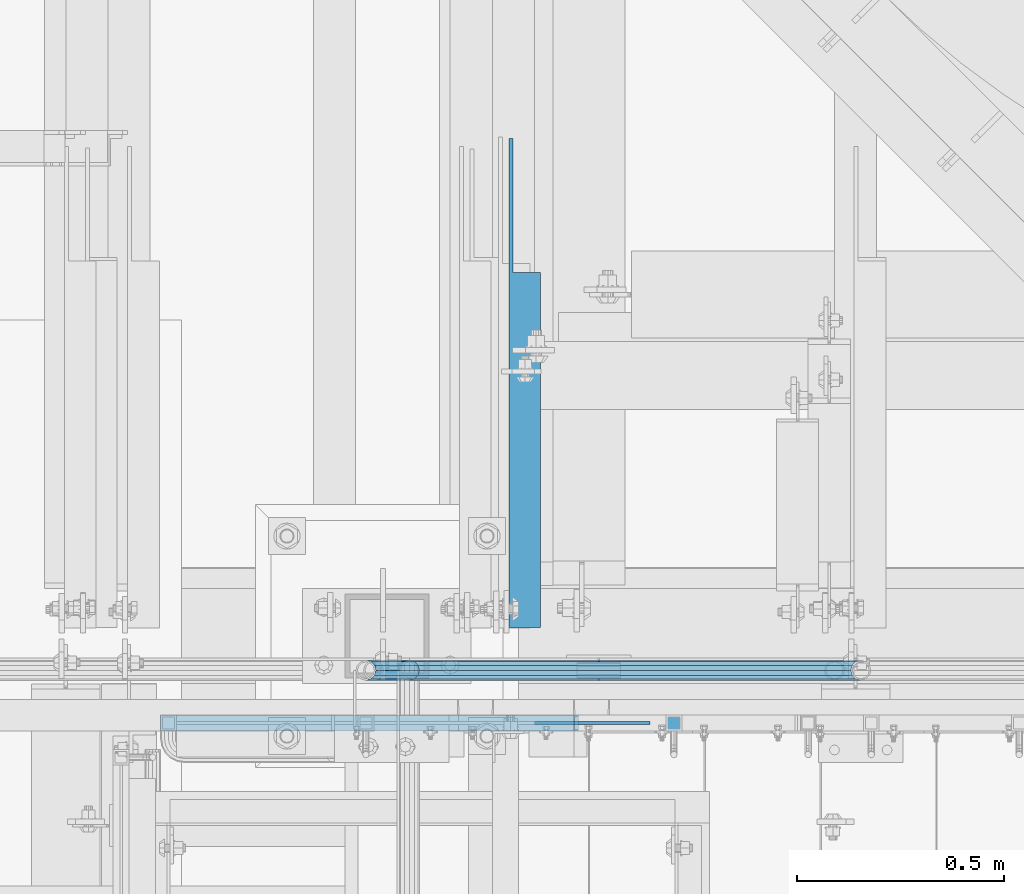
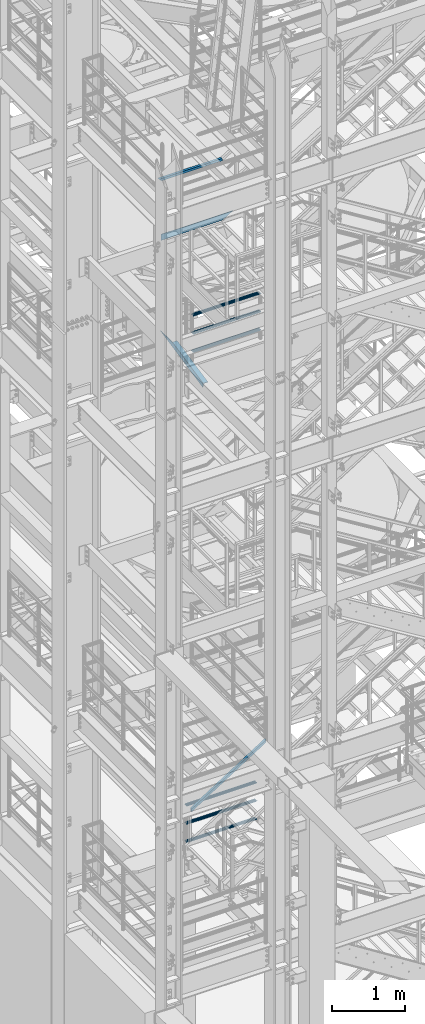
# One storey, part 967 of 1876: 9 beams, 1 member, 5 elements without a shape of their own.
"""IFC2X3 building model written with IfcOpenShell, lengths in millimetres."""

from ifc_helpers import new_model, si_unit, frame, origin_with_axes, place, context, subcontext, project, spatial, faceted_brep, material, type_object, element, aggregate, save


model = new_model("IFC2X3")

# Units and contexts
model_context = context("Model", 3, precision=1e-05, world=origin_with_axes())
body_context = subcontext(model_context, "Body", "Model", "MODEL_VIEW")
ifc_project = project(units=[si_unit("LENGTHUNIT", "METRE", prefix="MILLI"), si_unit("AREAUNIT", "SQUARE_METRE"), si_unit("VOLUMEUNIT", "CUBIC_METRE"), si_unit("MASSUNIT", "GRAM", prefix="KILO"), si_unit("TIMEUNIT", "SECOND"), si_unit("PLANEANGLEUNIT", "RADIAN"), si_unit("SOLIDANGLEUNIT", "STERADIAN"), si_unit("THERMODYNAMICTEMPERATUREUNIT", "DEGREE_CELSIUS"), si_unit("LUMINOUSINTENSITYUNIT", "LUMEN")], contexts=[model_context])

# Site, building, storey
site_placement = place(None, origin_with_axes())
site = spatial("IfcSite", under=ifc_project, at=site_placement, CompositionType="ELEMENT")
building_placement = place(site_placement, origin_with_axes())
building = spatial("IfcBuilding", under=site, at=building_placement, Name="Undefined", CompositionType="ELEMENT")
storey_placement = place(building_placement, origin_with_axes())
storey = spatial("IfcBuildingStorey", under=building, at=storey_placement, Name="Undefined", CompositionType="ELEMENT", Elevation=0.0)

# Assembly, beams
assembly_1_placement = place(storey_placement, origin_with_axes())
assembly_1 = element("IfcElementAssembly", 1, at=assembly_1_placement, inside=storey, Name="RAIL", AssemblyPlace="NOTDEFINED", PredefinedType="RIGID_FRAME")
ifc_material_1 = material()
beam_type_1 = type_object("IfcBeamType", Name="PIPE1-1/2SCH40", PredefinedType="NOTDEFINED")
beam_1_placement = place(assembly_1_placement, frame((2870.19999998821, -4654.55000114568, 13471.525), z_axis=(0.0, 0.0, 1.0), x_axis=(-1.0, 0.0, 0.0)))
beam_1 = element("IfcBeam", 2, at=beam_1_placement, type_object=beam_type_1, material=ifc_material_1, Name="RAIL", ObjectType="PIPE1-1/2SCH40", context=body_context, shape_type="Brep", body=[
    faceted_brep([(1068.12780699489, -12.0649999999996, 20.8971929933177), (1068.12780699489, -12.064999999986, 15.8661214311942), (1067.63437855703, -10.2235000000001, 17.7076214311801), (1064.89499998821, 0.0, 20.4470000000001), (1064.89499998821, 0.0, 24.1299999999992), (1067.63437855703, 10.2235000000001, 17.7076214311801), (1068.12780699489, 12.0650000000132, 15.8661214311669), (1068.12780699489, 12.0649999999996, 20.8971929933177), (1089.02499998822, 24.1300000000001, 0.0), (1076.95999998821, 20.8971929933186, 12.0650000000005), (1076.95999998821, 20.8971929933186, -12.0650000000005), (1073.77042842606, 17.7076214311801, 10.2235000000001), (1076.50980699488, 20.4470000000001, 0.0), (1073.77042842606, 17.7076214311801, -10.2235000000001), (1068.12780699489, 12.0650000000132, -15.8661214311669), (1068.12780699489, 12.0649999999996, -20.8971929933177), (1067.63437855703, 10.2235000000001, -17.7076214311801), (1064.89499998821, 0.0, -20.4470000000001), (1064.89499998821, 0.0, -24.1299999999992), (1068.12780699489, -12.064999999986, -15.8661214311942), (1068.12780699489, -12.0649999999996, -20.8971929933177), (1067.63437855703, -10.2235000000001, -17.7076214311801), (1089.02499998821, -24.1299999999865, 0.0), (1076.95999998821, -20.8971929933186, -12.0650000000005), (1076.95999998821, -20.8971929933186, 12.0650000000005), (1073.77042842609, -17.7076214311801, -10.2235000000001), (1076.50980699491, -20.4470000000001, 0.0), (1073.77042842609, -17.7076214311801, 10.2235000000001), (12.0650000000064, -20.8971929933177, -12.0649999999987), (20.8971929933249, -12.0650000000005, -20.8971929933177), (0.0, 24.1299999999992, 0.0), (12.0650000000064, 20.8971929933177, -12.0649999999987), (12.0650000000064, 20.8971929933177, 12.0649999999987), (20.8971929933249, 12.0650000000005, 20.8971929933177), (24.1300000000064, 0.0, 24.130000000001), (20.8971929933249, 12.0650000000005, -20.8971929933177), (24.1300000000063, 0.0, -24.130000000001), (24.1300000000063, 0.0, -20.4470000000001), (20.8971929933249, -12.0650000000005, -15.8661214311796), (21.3906214311868, -10.2235000000001, -17.7076214311819), (21.3906214311868, 10.2235000000001, -17.7076214311819), (20.8971929933249, 12.0650000000005, -15.8661214311796), (15.2545715621445, 17.7076214311801, -10.2235000000001), (12.5151929933249, 20.4470000000001, 0.0), (15.2545715621445, 17.7076214311801, 10.2235000000001), (20.8971929933249, 12.0650000000005, 15.8661214311796), (21.3906214311868, 10.2235000000001, 17.7076214311819), (24.1300000000064, 0.0, 20.4470000000001), (21.3906214311868, -10.2235000000001, 17.7076214311819), (20.8971929933249, -12.0650000000005, 15.8661214311796), (20.8971929933249, -12.0650000000005, 20.8971929933177), (12.0650000000064, -20.8971929933177, 12.0649999999987), (0.0, -24.1299999999992, 0.0), (15.2545715621445, -17.7076214311801, 10.2235000000001), (12.5151929933249, -20.4470000000001, 0.0), (15.2545715621445, -17.7076214311801, -10.2235000000001)], [[[0, 1, 2, 3, 4]], [[4, 3, 5, 6, 7]], [[8, 9, 10]], [[7, 6, 11, 12, 13, 14, 15, 10, 9]], [[16, 17, 18, 15, 14]], [[19, 20, 18, 17, 21]], [[22, 23, 24]], [[24, 23, 20, 19, 25, 26, 27, 1, 0]], [[28, 29, 20, 23]], [[30, 31, 32]], [[33, 34, 4, 7]], [[32, 33, 7, 9]], [[30, 32, 9, 8]], [[31, 30, 8, 10]], [[35, 31, 10, 15]], [[36, 35, 15, 18]], [[29, 36, 18, 20]], [[37, 36, 29, 38, 39]], [[40, 41, 35, 36, 37]], [[32, 31, 35, 41, 42, 43, 44, 45, 33]], [[33, 45, 46, 47, 34]], [[34, 47, 48, 49, 50]], [[34, 50, 0, 4]], [[50, 51, 24, 0]], [[51, 52, 22, 24]], [[52, 28, 23, 22]], [[51, 28, 52]], [[50, 49, 53, 54, 55, 38, 29, 28, 51]], [[55, 54, 26, 25]], [[21, 39, 38, 55, 25, 19]], [[37, 39, 21, 17]], [[40, 37, 17, 16]], [[42, 41, 40, 16, 14, 13]], [[43, 42, 13, 12]], [[44, 43, 12, 11]], [[5, 46, 45, 44, 11, 6]], [[47, 46, 5, 3]], [[48, 47, 3, 2]], [[53, 49, 48, 2, 1, 27]], [[54, 53, 27, 26]]]),
])
beam_2_placement = place(assembly_1_placement, frame((1781.17499999998, -4654.55000114569, 13776.325), z_axis=(0.0, 0.0, -1.0), x_axis=(1.0, 0.0, 0.0)))
beam_2 = element("IfcBeam", 3, at=beam_2_placement, type_object=beam_type_1, material=ifc_material_1, Name="RAIL", ObjectType="PIPE1-1/2SCH40", context=body_context, shape_type="Brep", body=[
    faceted_brep([(0.0, 24.1299999999992, 0.0), (12.0650000000064, 20.8971929933177, -12.0649999999987), (12.0650000000064, 20.8971929933177, 12.0649999999987), (12.0650000000064, -20.8971929933177, 12.0649999999987), (12.0650000000064, -20.8971929933177, -12.0649999999987), (0.0, -24.1299999999992, 0.0), (20.8971929933249, -12.0650000000005, 20.8971929933177), (20.8971929933249, -12.0650000000005, 15.8661214311796), (15.2545715621445, -17.7076214311801, 10.2235000000001), (12.5151929933249, -20.4470000000001, 0.0), (15.2545715621445, -17.7076214311801, -10.2235000000001), (20.8971929933249, -12.0650000000005, -15.8661214311796), (20.8971929933249, -12.0650000000005, -20.8971929933177), (24.1300000000063, 0.0, -20.4470000000001), (24.1300000000063, 0.0, -24.130000000001), (21.3906214311868, -10.2235000000001, -17.7076214311819), (21.3906214311868, 10.2235000000001, -17.7076214311819), (20.8971929933249, 12.0650000000005, -15.8661214311796), (20.8971929933249, 12.0650000000005, -20.8971929933177), (15.2545715621445, 17.7076214311801, -10.2235000000001), (12.5151929933249, 20.4470000000001, 0.0), (15.2545715621445, 17.7076214311801, 10.2235000000001), (20.8971929933249, 12.0650000000005, 15.8661214311796), (20.8971929933249, 12.0650000000005, 20.8971929933177), (21.3906214311868, 10.2235000000001, 17.7076214311819), (24.1300000000064, 0.0, 20.4470000000001), (24.1300000000064, 0.0, 24.130000000001), (21.3906214311868, -10.2235000000001, 17.7076214311819), (1089.02499998822, 24.1300000000001, 0.0), (1076.95999998821, 20.8971929933186, -12.0650000000005), (1068.12780699489, 12.0649999999996, -20.8971929933177), (1089.02499998821, -24.1299999999865, 0.0), (1076.95999998821, -20.8971929933186, -12.0650000000005), (1076.95999998821, -20.8971929933186, 12.0650000000005), (1068.12780699489, -12.0649999999996, 20.8971929933177), (1068.12780699489, -12.0649999999996, -20.8971929933177), (1064.89499998821, 0.0, -24.1299999999992), (1067.63437855703, 10.2235000000001, -17.7076214311801), (1064.89499998821, 0.0, -20.4470000000001), (1068.12780699489, 12.0650000000132, -15.8661214311669), (1068.12780699489, -12.064999999986, -15.8661214311942), (1067.63437855703, -10.2235000000001, -17.7076214311801), (1073.77042842609, -17.7076214311801, -10.2235000000001), (1076.50980699491, -20.4470000000001, 0.0), (1073.77042842609, -17.7076214311801, 10.2235000000001), (1068.12780699489, -12.064999999986, 15.8661214311942), (1067.63437855703, -10.2235000000001, 17.7076214311801), (1064.89499998821, 0.0, 20.4470000000001), (1064.89499998821, 0.0, 24.1299999999992), (1068.12780699489, 12.0649999999996, 20.8971929933177), (1076.95999998821, 20.8971929933186, 12.0650000000005), (1068.12780699489, 12.0650000000132, 15.8661214311669), (1073.77042842606, 17.7076214311801, 10.2235000000001), (1076.50980699488, 20.4470000000001, 0.0), (1073.77042842606, 17.7076214311801, -10.2235000000001), (1067.63437855703, 10.2235000000001, 17.7076214311801)], [[[0, 1, 2]], [[3, 4, 5]], [[6, 7, 8, 9, 10, 11, 12, 4, 3]], [[13, 14, 12, 11, 15]], [[16, 17, 18, 14, 13]], [[2, 1, 18, 17, 19, 20, 21, 22, 23]], [[23, 22, 24, 25, 26]], [[26, 25, 27, 7, 6]], [[1, 0, 28, 29]], [[18, 1, 29, 30]], [[31, 32, 33]], [[6, 3, 33, 34]], [[3, 5, 31, 33]], [[5, 4, 32, 31]], [[4, 12, 35, 32]], [[12, 14, 36, 35]], [[14, 18, 30, 36]], [[37, 38, 36, 30, 39]], [[40, 35, 36, 38, 41]], [[33, 32, 35, 40, 42, 43, 44, 45, 34]], [[34, 45, 46, 47, 48]], [[26, 6, 34, 48]], [[2, 23, 49, 50]], [[23, 26, 48, 49]], [[0, 2, 50, 28]], [[28, 50, 29]], [[49, 51, 52, 53, 54, 39, 30, 29, 50]], [[48, 47, 55, 51, 49]], [[25, 24, 55, 47]], [[55, 24, 22, 21, 52, 51]], [[21, 20, 53, 52]], [[20, 19, 54, 53]], [[19, 17, 16, 37, 39, 54]], [[16, 13, 38, 37]], [[13, 15, 41, 38]], [[41, 15, 11, 10, 42, 40]], [[10, 9, 43, 42]], [[9, 8, 44, 43]], [[8, 7, 27, 46, 45, 44]], [[27, 25, 47, 46]]]),
])
beam_3_placement = place(assembly_1_placement, frame((1781.17499999998, -4654.55000114569, 14081.125), z_axis=(0.0, 0.0, -1.0), x_axis=(1.0, 0.0, 0.0)))
beam_3 = element("IfcBeam", 4, at=beam_3_placement, type_object=beam_type_1, material=ifc_material_1, Name="RAIL", ObjectType="PIPE1-1/2SCH40", context=body_context, shape_type="Brep", body=[
    faceted_brep([(0.0, 24.1299999999992, 0.0), (12.0650000000064, 20.8971929933177, -12.0649999999987), (12.0650000000064, 20.8971929933177, 12.0649999999987), (12.0650000000064, -20.8971929933177, 12.0649999999987), (12.0650000000064, -20.8971929933177, -12.0649999999987), (0.0, -24.1299999999992, 0.0), (20.8971929933249, -12.0650000000005, 20.8971929933177), (20.8971929933249, -12.0650000000005, 15.8661214311796), (15.2545715621445, -17.7076214311801, 10.2235000000001), (12.5151929933249, -20.4470000000001, 0.0), (15.2545715621445, -17.7076214311801, -10.2235000000001), (20.8971929933249, -12.0650000000005, -15.8661214311796), (20.8971929933249, -12.0650000000005, -20.8971929933177), (24.1300000000063, 0.0, -20.4470000000001), (24.1300000000063, 0.0, -24.130000000001), (21.3906214311868, -10.2235000000001, -17.7076214311819), (21.3906214311868, 10.2235000000001, -17.7076214311819), (20.8971929933249, 12.0650000000005, -15.8661214311796), (20.8971929933249, 12.0650000000005, -20.8971929933177), (15.2545715621445, 17.7076214311801, -10.2235000000001), (12.5151929933249, 20.4470000000001, 0.0), (15.2545715621445, 17.7076214311801, 10.2235000000001), (20.8971929933249, 12.0650000000005, 15.8661214311796), (20.8971929933249, 12.0650000000005, 20.8971929933177), (21.3906214311868, 10.2235000000001, 17.7076214311819), (24.1300000000064, 0.0, 20.4470000000001), (24.1300000000064, 0.0, 24.130000000001), (21.3906214311868, -10.2235000000001, 17.7076214311819), (1089.02499998822, 24.1300000000001, 0.0), (1076.95999998821, 20.8971929933186, -12.0650000000005), (1068.12780699489, 12.0649999999996, -20.8971929933177), (1089.02499998821, -24.1299999999865, 0.0), (1076.95999998821, -20.8971929933186, -12.0650000000005), (1076.95999998821, -20.8971929933186, 12.0650000000005), (1068.12780699489, -12.0649999999996, 20.8971929933177), (1068.12780699489, -12.0649999999996, -20.8971929933177), (1064.89499998821, 0.0, -24.1299999999992), (1067.63437855703, 10.2235000000001, -17.7076214311801), (1064.89499998821, 0.0, -20.4470000000001), (1068.12780699489, 12.0650000000132, -15.8661214311669), (1068.12780699489, -12.064999999986, -15.8661214311942), (1067.63437855703, -10.2235000000001, -17.7076214311801), (1073.77042842609, -17.7076214311801, -10.2235000000001), (1076.50980699491, -20.4470000000001, 0.0), (1073.77042842609, -17.7076214311801, 10.2235000000001), (1068.12780699489, -12.064999999986, 15.8661214311942), (1067.63437855703, -10.2235000000001, 17.7076214311801), (1064.89499998821, 0.0, 20.4470000000001), (1064.89499998821, 0.0, 24.1299999999992), (1068.12780699489, 12.0649999999996, 20.8971929933177), (1076.95999998821, 20.8971929933186, 12.0650000000005), (1068.12780699489, 12.0650000000132, 15.8661214311669), (1073.77042842606, 17.7076214311801, 10.2235000000001), (1076.50980699488, 20.4470000000001, 0.0), (1073.77042842606, 17.7076214311801, -10.2235000000001), (1067.63437855703, 10.2235000000001, 17.7076214311801)], [[[0, 1, 2]], [[3, 4, 5]], [[6, 7, 8, 9, 10, 11, 12, 4, 3]], [[13, 14, 12, 11, 15]], [[16, 17, 18, 14, 13]], [[2, 1, 18, 17, 19, 20, 21, 22, 23]], [[23, 22, 24, 25, 26]], [[26, 25, 27, 7, 6]], [[1, 0, 28, 29]], [[18, 1, 29, 30]], [[31, 32, 33]], [[6, 3, 33, 34]], [[3, 5, 31, 33]], [[5, 4, 32, 31]], [[4, 12, 35, 32]], [[12, 14, 36, 35]], [[14, 18, 30, 36]], [[37, 38, 36, 30, 39]], [[40, 35, 36, 38, 41]], [[33, 32, 35, 40, 42, 43, 44, 45, 34]], [[34, 45, 46, 47, 48]], [[26, 6, 34, 48]], [[2, 23, 49, 50]], [[23, 26, 48, 49]], [[0, 2, 50, 28]], [[28, 50, 29]], [[49, 51, 52, 53, 54, 39, 30, 29, 50]], [[48, 47, 55, 51, 49]], [[25, 24, 55, 47]], [[55, 24, 22, 21, 52, 51]], [[21, 20, 53, 52]], [[20, 19, 54, 53]], [[19, 17, 16, 37, 39, 54]], [[16, 13, 38, 37]], [[13, 15, 41, 38]], [[41, 15, 11, 10, 42, 40]], [[10, 9, 43, 42]], [[9, 8, 44, 43]], [[8, 7, 27, 46, 45, 44]], [[27, 25, 47, 46]]]),
])
aggregate(assembly_1, [beam_1, beam_2, beam_3])

assembly_2_placement = place(storey_placement, origin_with_axes())
assembly_2 = element("IfcElementAssembly", 5, at=assembly_2_placement, inside=storey, Name="RAIL", AssemblyPlace="NOTDEFINED", PredefinedType="RIGID_FRAME")
beam_4_placement = place(assembly_2_placement, frame((1676.40000031138, -4654.55000114549, 5292.725), z_axis=(0.0, 0.0, 1.0), x_axis=(1.0, 0.0, 0.0)))
beam_4 = element("IfcBeam", 6, at=beam_4_placement, type_object=beam_type_1, material=ifc_material_1, Name="RAIL", ObjectType="PIPE1-1/2SCH40", context=body_context, shape_type="Brep", body=[
    faceted_brep([(1109.40280692884, -12.0649999999996, 20.8971929933186), (1109.40280692884, -12.0650000000269, 15.8661214311533), (1108.90937849097, -10.2235000000001, 17.7076214311801), (1106.16999992216, -9.09494701772928e-13, 20.4470000000001), (1106.16999992216, -9.09494701772928e-13, 24.1300000000001), (1108.90937849099, 10.2235000000001, 17.7076214311801), (1109.40280692884, 12.0649999999723, 15.8661214312078), (1109.40280692884, 12.0649999999996, 20.8971929933186), (1130.29999992215, 24.1300000000001, 0.0), (1118.23499992216, 20.8971929933186, 12.0649999999996), (1118.23499992216, 20.8971929933186, -12.0649999999996), (1115.04542836005, 17.7076214311801, 10.2235000000001), (1117.78480692887, 20.4470000000001, 0.0), (1115.04542836005, 17.7076214311801, -10.2235000000001), (1109.40280692884, 12.0649999999723, -15.8661214312078), (1109.40280692884, 12.0649999999996, -20.8971929933186), (1108.90937849099, 10.2235000000001, -17.7076214311801), (1106.16999992216, 0.0, -20.4470000000001), (1106.16999992216, 0.0, -24.1300000000001), (1109.40280692884, -12.0650000000269, -15.8661214311533), (1109.40280692884, -12.0649999999996, -20.8971929933186), (1108.90937849097, -10.2235000000001, -17.7076214311801), (1130.29999992216, -24.1300000000274, 0.0), (1118.23499992216, -20.8971929933186, -12.0649999999996), (1118.23499992216, -20.8971929933186, 12.0649999999996), (1115.04542835999, -17.7076214311801, -10.2235000000001), (1117.78480692881, -20.4470000000001, 0.0), (1115.04542835999, -17.7076214311801, 10.2235000000001), (12.0650000000064, -20.8971929933177, -12.0649999999987), (20.8971929933249, -12.0650000000005, -20.8971929933177), (0.0, 24.1299999999992, 0.0), (12.0650000000064, 20.8971929933177, -12.0649999999987), (12.0650000000064, 20.8971929933177, 12.0649999999987), (20.8971929933249, 12.0650000000005, 20.8971929933177), (24.1300000000064, 0.0, 24.130000000001), (20.8971929933249, 12.0650000000005, -20.8971929933177), (24.1300000000063, 0.0, -24.130000000001), (24.1300000000063, 0.0, -20.4470000000001), (20.8971929933249, -12.0650000000005, -15.8661214311796), (21.3906214311868, -10.2235000000001, -17.7076214311819), (21.3906214311868, 10.2235000000001, -17.7076214311819), (20.8971929933249, 12.0650000000005, -15.8661214311796), (15.2545715621445, 17.7076214311801, -10.2235000000001), (12.5151929933249, 20.4470000000001, 0.0), (15.2545715621445, 17.7076214311801, 10.2235000000001), (20.8971929933249, 12.0650000000005, 15.8661214311796), (21.3906214311868, 10.2235000000001, 17.7076214311819), (24.1300000000064, 0.0, 20.4470000000001), (21.3906214311868, -10.2235000000001, 17.7076214311819), (20.8971929933249, -12.0650000000005, 15.8661214311796), (20.8971929933249, -12.0650000000005, 20.8971929933177), (12.0650000000064, -20.8971929933177, 12.0649999999987), (0.0, -24.1299999999992, 0.0), (15.2545715621445, -17.7076214311801, 10.2235000000001), (12.5151929933249, -20.4470000000001, 0.0), (15.2545715621445, -17.7076214311801, -10.2235000000001)], [[[0, 1, 2, 3, 4]], [[4, 3, 5, 6, 7]], [[8, 9, 10]], [[7, 6, 11, 12, 13, 14, 15, 10, 9]], [[16, 17, 18, 15, 14]], [[19, 20, 18, 17, 21]], [[22, 23, 24]], [[24, 23, 20, 19, 25, 26, 27, 1, 0]], [[28, 29, 20, 23]], [[30, 31, 32]], [[33, 34, 4, 7]], [[32, 33, 7, 9]], [[30, 32, 9, 8]], [[31, 30, 8, 10]], [[35, 31, 10, 15]], [[36, 35, 15, 18]], [[29, 36, 18, 20]], [[37, 36, 29, 38, 39]], [[40, 41, 35, 36, 37]], [[32, 31, 35, 41, 42, 43, 44, 45, 33]], [[33, 45, 46, 47, 34]], [[34, 47, 48, 49, 50]], [[34, 50, 0, 4]], [[50, 51, 24, 0]], [[51, 52, 22, 24]], [[52, 28, 23, 22]], [[51, 28, 52]], [[50, 49, 53, 54, 55, 38, 29, 28, 51]], [[55, 54, 26, 25]], [[21, 39, 38, 55, 25, 19]], [[37, 39, 21, 17]], [[40, 37, 17, 16]], [[42, 41, 40, 16, 14, 13]], [[43, 42, 13, 12]], [[44, 43, 12, 11]], [[5, 46, 45, 44, 11, 6]], [[47, 46, 5, 3]], [[48, 47, 3, 2]], [[53, 49, 48, 2, 1, 27]], [[54, 53, 27, 26]]]),
])
beam_5_placement = place(assembly_2_placement, frame((2806.70000023354, -4654.55000114549, 5597.525), z_axis=(0.0, 0.0, -1.0), x_axis=(-1.0, 0.0, 0.0)))
beam_5 = element("IfcBeam", 7, at=beam_5_placement, type_object=beam_type_1, material=ifc_material_1, Name="RAIL", ObjectType="PIPE1-1/2SCH40", context=body_context, shape_type="Brep", body=[
    faceted_brep([(0.0, 24.1299999999992, 0.0), (12.0650000000064, 20.8971929933177, -12.0649999999987), (12.0650000000064, 20.8971929933177, 12.0649999999987), (12.0650000000064, -20.8971929933177, 12.0649999999987), (12.0650000000064, -20.8971929933177, -12.0649999999987), (0.0, -24.1299999999992, 0.0), (20.8971929933249, -12.0650000000005, 20.8971929933177), (20.8971929933249, -12.0650000000005, 15.8661214311796), (15.2545715621445, -17.7076214311801, 10.2235000000001), (12.5151929933249, -20.4470000000001, 0.0), (15.2545715621445, -17.7076214311801, -10.2235000000001), (20.8971929933249, -12.0650000000005, -15.8661214311796), (20.8971929933249, -12.0650000000005, -20.8971929933177), (24.1300000000063, 0.0, -20.4470000000001), (24.1300000000063, 0.0, -24.130000000001), (21.3906214311868, -10.2235000000001, -17.7076214311819), (21.3906214311868, 10.2235000000001, -17.7076214311819), (20.8971929933249, 12.0650000000005, -15.8661214311796), (20.8971929933249, 12.0650000000005, -20.8971929933177), (15.2545715621445, 17.7076214311801, -10.2235000000001), (12.5151929933249, 20.4470000000001, 0.0), (15.2545715621445, 17.7076214311801, 10.2235000000001), (20.8971929933249, 12.0650000000005, 15.8661214311796), (20.8971929933249, 12.0650000000005, 20.8971929933177), (21.3906214311868, 10.2235000000001, 17.7076214311819), (24.1300000000064, 0.0, 20.4470000000001), (24.1300000000064, 0.0, 24.130000000001), (21.3906214311868, -10.2235000000001, 17.7076214311819), (1130.29999992215, 24.1300000000001, 0.0), (1118.23499992216, 20.8971929933186, -12.0649999999996), (1109.40280692884, 12.0649999999996, -20.8971929933186), (1130.29999992216, -24.1300000000274, 0.0), (1118.23499992216, -20.8971929933186, -12.0649999999996), (1118.23499992216, -20.8971929933186, 12.0649999999996), (1109.40280692884, -12.0649999999996, 20.8971929933186), (1109.40280692884, -12.0649999999996, -20.8971929933186), (1106.16999992216, 0.0, -24.1300000000001), (1108.90937849099, 10.2235000000001, -17.7076214311801), (1106.16999992216, 0.0, -20.4470000000001), (1109.40280692884, 12.0649999999723, -15.8661214312078), (1109.40280692884, -12.0650000000269, -15.8661214311533), (1108.90937849097, -10.2235000000001, -17.7076214311801), (1115.04542835999, -17.7076214311801, -10.2235000000001), (1117.78480692881, -20.4470000000001, 0.0), (1115.04542835999, -17.7076214311801, 10.2235000000001), (1109.40280692884, -12.0650000000269, 15.8661214311533), (1108.90937849097, -10.2235000000001, 17.7076214311801), (1106.16999992216, -9.09494701772928e-13, 20.4470000000001), (1106.16999992216, -9.09494701772928e-13, 24.1300000000001), (1109.40280692884, 12.0649999999996, 20.8971929933186), (1118.23499992216, 20.8971929933186, 12.0649999999996), (1109.40280692884, 12.0649999999723, 15.8661214312078), (1115.04542836005, 17.7076214311801, 10.2235000000001), (1117.78480692887, 20.4470000000001, 0.0), (1115.04542836005, 17.7076214311801, -10.2235000000001), (1108.90937849099, 10.2235000000001, 17.7076214311801)], [[[0, 1, 2]], [[3, 4, 5]], [[6, 7, 8, 9, 10, 11, 12, 4, 3]], [[13, 14, 12, 11, 15]], [[16, 17, 18, 14, 13]], [[2, 1, 18, 17, 19, 20, 21, 22, 23]], [[23, 22, 24, 25, 26]], [[26, 25, 27, 7, 6]], [[1, 0, 28, 29]], [[18, 1, 29, 30]], [[31, 32, 33]], [[6, 3, 33, 34]], [[3, 5, 31, 33]], [[5, 4, 32, 31]], [[4, 12, 35, 32]], [[12, 14, 36, 35]], [[14, 18, 30, 36]], [[37, 38, 36, 30, 39]], [[40, 35, 36, 38, 41]], [[33, 32, 35, 40, 42, 43, 44, 45, 34]], [[34, 45, 46, 47, 48]], [[26, 6, 34, 48]], [[2, 23, 49, 50]], [[23, 26, 48, 49]], [[0, 2, 50, 28]], [[28, 50, 29]], [[49, 51, 52, 53, 54, 39, 30, 29, 50]], [[48, 47, 55, 51, 49]], [[25, 24, 55, 47]], [[55, 24, 22, 21, 52, 51]], [[21, 20, 53, 52]], [[20, 19, 54, 53]], [[19, 17, 16, 37, 39, 54]], [[16, 13, 38, 37]], [[13, 15, 41, 38]], [[41, 15, 11, 10, 42, 40]], [[10, 9, 43, 42]], [[9, 8, 44, 43]], [[8, 7, 27, 46, 45, 44]], [[27, 25, 47, 46]]]),
])
beam_6_placement = place(assembly_2_placement, frame((2806.70000023354, -4654.55000114549, 5902.325), z_axis=(0.0, 0.0, -1.0), x_axis=(-1.0, 0.0, 0.0)))
beam_6 = element("IfcBeam", 8, at=beam_6_placement, type_object=beam_type_1, material=ifc_material_1, Name="RAIL", ObjectType="PIPE1-1/2SCH40", context=body_context, shape_type="Brep", body=[
    faceted_brep([(0.0, 24.1299999999992, 0.0), (12.0650000000064, 20.8971929933177, -12.0649999999987), (12.0650000000064, 20.8971929933177, 12.0649999999987), (12.0650000000064, -20.8971929933177, 12.0649999999987), (12.0650000000064, -20.8971929933177, -12.0649999999987), (0.0, -24.1299999999992, 0.0), (20.8971929933249, -12.0650000000005, 20.8971929933177), (20.8971929933249, -12.0650000000005, 15.8661214311796), (15.2545715621445, -17.7076214311801, 10.2235000000001), (12.5151929933249, -20.4470000000001, 0.0), (15.2545715621445, -17.7076214311801, -10.2235000000001), (20.8971929933249, -12.0650000000005, -15.8661214311796), (20.8971929933249, -12.0650000000005, -20.8971929933177), (24.1300000000063, 0.0, -20.4470000000001), (24.1300000000063, 0.0, -24.130000000001), (21.3906214311868, -10.2235000000001, -17.7076214311819), (21.3906214311868, 10.2235000000001, -17.7076214311819), (20.8971929933249, 12.0650000000005, -15.8661214311796), (20.8971929933249, 12.0650000000005, -20.8971929933177), (15.2545715621445, 17.7076214311801, -10.2235000000001), (12.5151929933249, 20.4470000000001, 0.0), (15.2545715621445, 17.7076214311801, 10.2235000000001), (20.8971929933249, 12.0650000000005, 15.8661214311796), (20.8971929933249, 12.0650000000005, 20.8971929933177), (21.3906214311868, 10.2235000000001, 17.7076214311819), (24.1300000000064, 0.0, 20.4470000000001), (24.1300000000064, 0.0, 24.130000000001), (21.3906214311868, -10.2235000000001, 17.7076214311819), (1130.29999992215, 24.1300000000001, 0.0), (1118.23499992216, 20.8971929933186, -12.0649999999996), (1109.40280692884, 12.0649999999996, -20.8971929933186), (1130.29999992216, -24.1300000000274, 0.0), (1118.23499992216, -20.8971929933186, -12.0649999999996), (1118.23499992216, -20.8971929933186, 12.0649999999996), (1109.40280692884, -12.0649999999996, 20.8971929933186), (1109.40280692884, -12.0649999999996, -20.8971929933186), (1106.16999992216, 0.0, -24.1300000000001), (1108.90937849099, 10.2235000000001, -17.7076214311801), (1106.16999992216, 0.0, -20.4470000000001), (1109.40280692884, 12.0649999999723, -15.8661214312078), (1109.40280692884, -12.0650000000269, -15.8661214311533), (1108.90937849097, -10.2235000000001, -17.7076214311801), (1115.04542835999, -17.7076214311801, -10.2235000000001), (1117.78480692881, -20.4470000000001, 0.0), (1115.04542835999, -17.7076214311801, 10.2235000000001), (1109.40280692884, -12.0650000000269, 15.8661214311533), (1108.90937849097, -10.2235000000001, 17.7076214311801), (1106.16999992216, -9.09494701772928e-13, 20.4470000000001), (1106.16999992216, -9.09494701772928e-13, 24.1300000000001), (1109.40280692884, 12.0649999999996, 20.8971929933186), (1118.23499992216, 20.8971929933186, 12.0649999999996), (1109.40280692884, 12.0649999999723, 15.8661214312078), (1115.04542836005, 17.7076214311801, 10.2235000000001), (1117.78480692887, 20.4470000000001, 0.0), (1115.04542836005, 17.7076214311801, -10.2235000000001), (1108.90937849099, 10.2235000000001, 17.7076214311801)], [[[0, 1, 2]], [[3, 4, 5]], [[6, 7, 8, 9, 10, 11, 12, 4, 3]], [[13, 14, 12, 11, 15]], [[16, 17, 18, 14, 13]], [[2, 1, 18, 17, 19, 20, 21, 22, 23]], [[23, 22, 24, 25, 26]], [[26, 25, 27, 7, 6]], [[1, 0, 28, 29]], [[18, 1, 29, 30]], [[31, 32, 33]], [[6, 3, 33, 34]], [[3, 5, 31, 33]], [[5, 4, 32, 31]], [[4, 12, 35, 32]], [[12, 14, 36, 35]], [[14, 18, 30, 36]], [[37, 38, 36, 30, 39]], [[40, 35, 36, 38, 41]], [[33, 32, 35, 40, 42, 43, 44, 45, 34]], [[34, 45, 46, 47, 48]], [[26, 6, 34, 48]], [[2, 23, 49, 50]], [[23, 26, 48, 49]], [[0, 2, 50, 28]], [[28, 50, 29]], [[49, 51, 52, 53, 54, 39, 30, 29, 50]], [[48, 47, 55, 51, 49]], [[25, 24, 55, 47]], [[55, 24, 22, 21, 52, 51]], [[21, 20, 53, 52]], [[20, 19, 54, 53]], [[19, 17, 16, 37, 39, 54]], [[16, 13, 38, 37]], [[13, 15, 41, 38]], [[41, 15, 11, 10, 42, 40]], [[10, 9, 43, 42]], [[9, 8, 44, 43]], [[8, 7, 27, 46, 45, 44]], [[27, 25, 47, 46]]]),
])
aggregate(assembly_2, [beam_4, beam_5, beam_6])

# Assembly, beam
assembly_3_placement = place(storey_placement, origin_with_axes())
assembly_3 = element("IfcElementAssembly", 9, at=assembly_3_placement, inside=storey, Name="RAIL", AssemblyPlace="NOTDEFINED", PredefinedType="RIGID_FRAME")
ifc_material_2 = material(Name="STEEL/A36")
beam_type_2 = type_object("IfcBeamType", PredefinedType="NOTDEFINED")
beam_7_placement = place(assembly_3_placement, frame((1219.19999913175, -4781.55000191422, 15658.2768514434), z_axis=(0.0, 0.0, 1.0), x_axis=(1.0, 0.0, 0.0)))
beam_7 = element("IfcBeam", 10, at=beam_7_placement, type_object=beam_type_2, material=ifc_material_2, Name="PLATE", context=body_context, shape_type="Brep", body=[
    faceted_brep([(0.0, 3.17500000000018, -50.8000000000002), (0.0, 3.17500000000018, 50.8000000000002), (1142.46466130154, 3.17500000000018, 50.7999999999993), (978.469009159079, 3.17500000000018, -50.7999999999993), (0.0, -3.17500000000018, 50.8000000000002), (1142.46466130154, -3.17500000000018, 50.7999999999993), (0.0, -3.17500000000018, -50.8000000000002), (978.469009159079, -3.17500000000018, -50.7999999999993)], [[[0, 1, 2, 3]], [[1, 4, 5, 2]], [[4, 6, 7, 5]], [[6, 0, 3, 7]], [[5, 7, 3, 2]], [[6, 4, 1, 0]]]),
])

assembly_4_placement = place(storey_placement, origin_with_axes())
assembly_4 = element("IfcElementAssembly", 11, at=assembly_4_placement, inside=storey, AssemblyPlace="NOTDEFINED", PredefinedType="RIGID_FRAME")
beam_type_3 = type_object("IfcBeamType", Name="L3X3X3/8", PredefinedType="NOTDEFINED")
beam_8_placement = place(assembly_4_placement, frame((2059.78153078443, -4564.12873652822, 12747.4821812721), z_axis=(1.0, 0.0, 0.0), x_axis=(0.0, 0.978426579374421, 0.206594842079058)))
beam_8 = element("IfcBeam", 12, at=beam_8_placement, type_object=beam_type_3, material=ifc_material_2, ObjectType="L3X3X3/8", context=body_context, shape_type="Brep", body=[
    faceted_brep([(21.092538210298, 38.1000000000149, -38.0999999999999), (21.092538210298, 38.1000000000149, 38.0999999999999), (849.923281178562, 38.0999999997057, 38.0999999999999), (849.923281178562, 38.0999999997057, -38.0999999999999), (21.0925382102962, 28.575000000008, 38.0999999999999), (895.033377223398, 28.574999999686, 38.0999999999999), (21.0925382102962, 28.575000000008, -28.575), (895.033377223398, 28.574999999686, -28.575), (21.0925382102835, -38.1000000000295, -28.575), (1210.80404953725, -38.1000000004697, -28.575), (21.0925382102835, -38.1000000000295, -38.0999999999999), (1210.80404953725, -38.1000000004697, -38.0999999999999)], [[[0, 1, 2, 3]], [[1, 4, 5, 2]], [[4, 6, 7, 5]], [[6, 8, 9, 7]], [[8, 10, 11, 9]], [[10, 0, 3, 11]], [[5, 7, 9, 11, 3, 2]], [[10, 8, 6, 4, 1, 0]]]),
])
aggregate(assembly_4, [beam_8])

# Beam
ifc_material_3 = material()
beam_type_4 = type_object("IfcBeamType", Name="HSS1-1/2X1-1/2X1/8", PredefinedType="NOTDEFINED")
beam_9_placement = place(assembly_3_placement, frame((2184.16517425803, -4781.55000114554, 16636.1768516284), z_axis=(0.0, 0.0, -1.0), x_axis=(-1.0, 0.0, 0.0)))
beam_9 = element("IfcBeam", 13, at=beam_9_placement, type_object=beam_type_4, material=ifc_material_3, Name="RAIL", ObjectType="HSS1-1/2X1-1/2X1/8", context=body_context, shape_type="Brep", body=[
    faceted_brep([(4.51879699173378, 15.8749992829999, -15.8749992830017), (4.51879699173378, -15.8749992829999, -15.8749992830017), (999.890173654401, -15.8749992829999, -15.8749992830017), (999.890173654401, 15.8749992829999, -15.8749992830017), (-4.51879699175015, -15.8749992829999, 15.8749992830017), (968.140175088402, -15.8749992829999, 15.8749992830017), (-4.51879699175015, 15.8749992829999, 15.8749992830017), (968.140175088402, 15.8749992829999, 15.8749992830017), (5.4225564172375, 19.0499992349996, -19.0499992350015), (-5.42255641725387, 19.0499992349996, 19.0499992350015), (964.965175136401, 19.0499992349996, 19.0499992350015), (1003.0651736064, 19.0499992349996, -19.0499992350015), (-5.42255641725387, -19.0499992349996, 19.0499992350015), (964.965175136401, -19.0499992349996, 19.0499992350015), (5.4225564172375, -19.0499992349996, -19.0499992350015), (1003.0651736064, -19.0499992349996, -19.0499992350015)], [[[0, 1, 2, 3]], [[1, 4, 5, 2]], [[4, 6, 7, 5]], [[6, 0, 3, 7]], [[8, 9, 10, 11]], [[9, 12, 13, 10]], [[12, 14, 15, 13]], [[14, 8, 11, 15]], [[13, 15, 11, 10], [5, 7, 3, 2]], [[14, 12, 9, 8], [6, 4, 1, 0]]]),
])

aggregate(assembly_3, [beam_7, beam_9])

# Assembly, member
assembly_5_placement = place(storey_placement, origin_with_axes())
assembly_5 = element("IfcElementAssembly", 14, at=assembly_5_placement, inside=storey, Name="RAIL", AssemblyPlace="NOTDEFINED", PredefinedType="RIGID_FRAME")
member_type = type_object("IfcMemberType", Name="HSS1-1/2X1-1/2X1/8", PredefinedType="NOTDEFINED")
member_placement = place(assembly_5_placement, frame((1657.35000107608, -4781.55000114554, 5871.72954587557), z_axis=(-0.536875491934336, 0.0, 0.843661487896813), x_axis=(0.843661487896813, 0.0, 0.536875491934336)))
member = element("IfcMember", 15, at=member_placement, type_object=member_type, material=ifc_material_3, Name="RAIL", ObjectType="HSS1-1/2X1-1/2X1/8", context=body_context, shape_type="Brep", body=[
    faceted_brep([(1457.25210239366, -19.0499992349996, 19.0499992353298), (1433.00664883827, -19.0499992349996, -19.0499992346649), (1433.00664883827, 19.0499992349996, -19.0499992346649), (1457.25210239366, 19.0499992349996, 19.0499992353298), (1455.23164788012, -15.8749992829999, 15.87499928333), (1455.23164788012, 15.8749992829999, 15.87499928333), (1435.02710335181, 15.8749992829999, -15.8749992826661), (1435.02710335181, -15.8749992829999, -15.8749992826661), (57.2830179808634, 19.0499992349996, 19.0499992350083), (57.2830179808634, -19.0499992349996, 19.0499992350083), (33.0375644254536, -19.0499992349996, -19.0499992349869), (33.0375644254536, 19.0499992349996, -19.0499992349869), (55.2625634673213, 15.8749992829999, 15.874999283008), (55.2625634673213, -15.8749992829999, 15.874999283008), (35.0580189389957, -15.8749992829999, -15.8749992829871), (35.0580189389957, 15.8749992829999, -15.8749992829871)], [[[0, 1, 2, 3], [4, 5, 6, 7]], [[8, 9, 0, 3]], [[10, 11, 2, 1]], [[9, 10, 1, 0]], [[11, 8, 3, 2]], [[10, 9, 8, 11], [12, 13, 14, 15]], [[14, 13, 4, 7]], [[15, 14, 7, 6]], [[12, 15, 6, 5]], [[13, 12, 5, 4]]]),
])
aggregate(assembly_5, [member])

save(model, "model.ifc")
